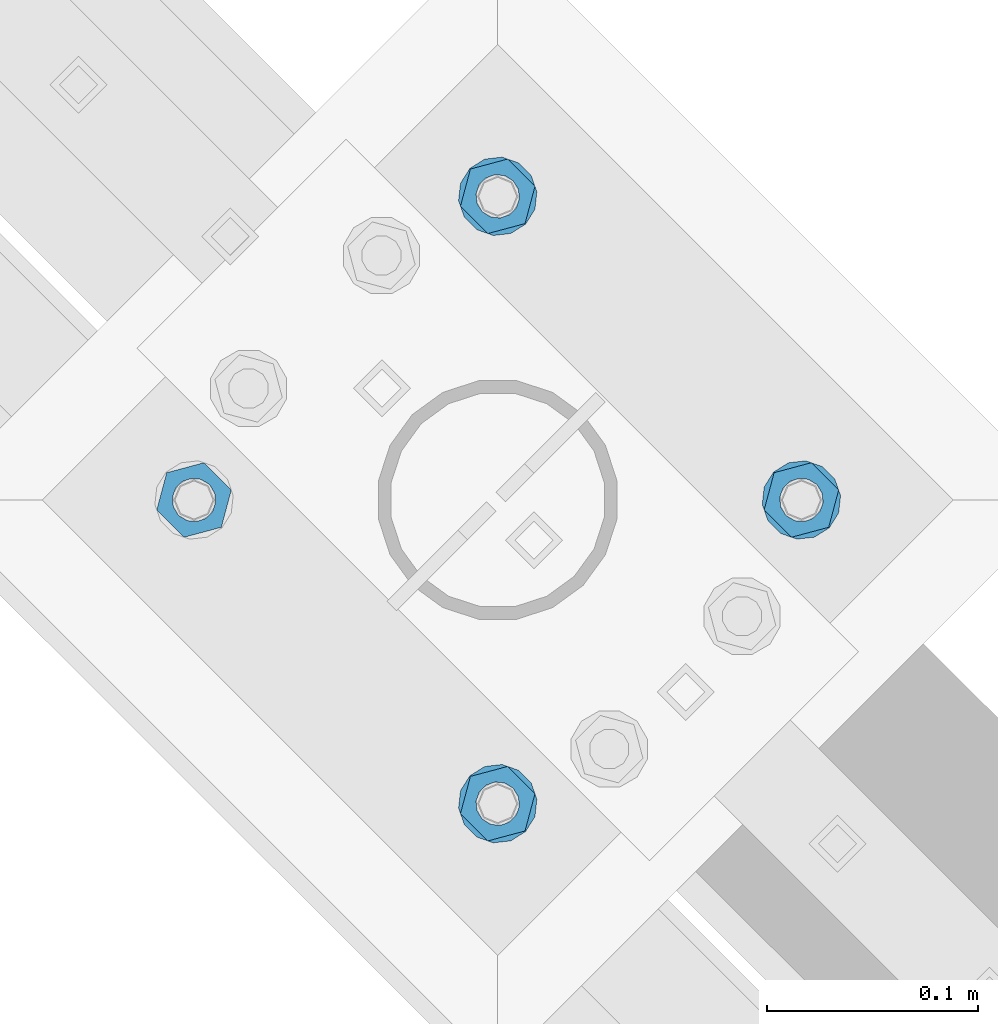
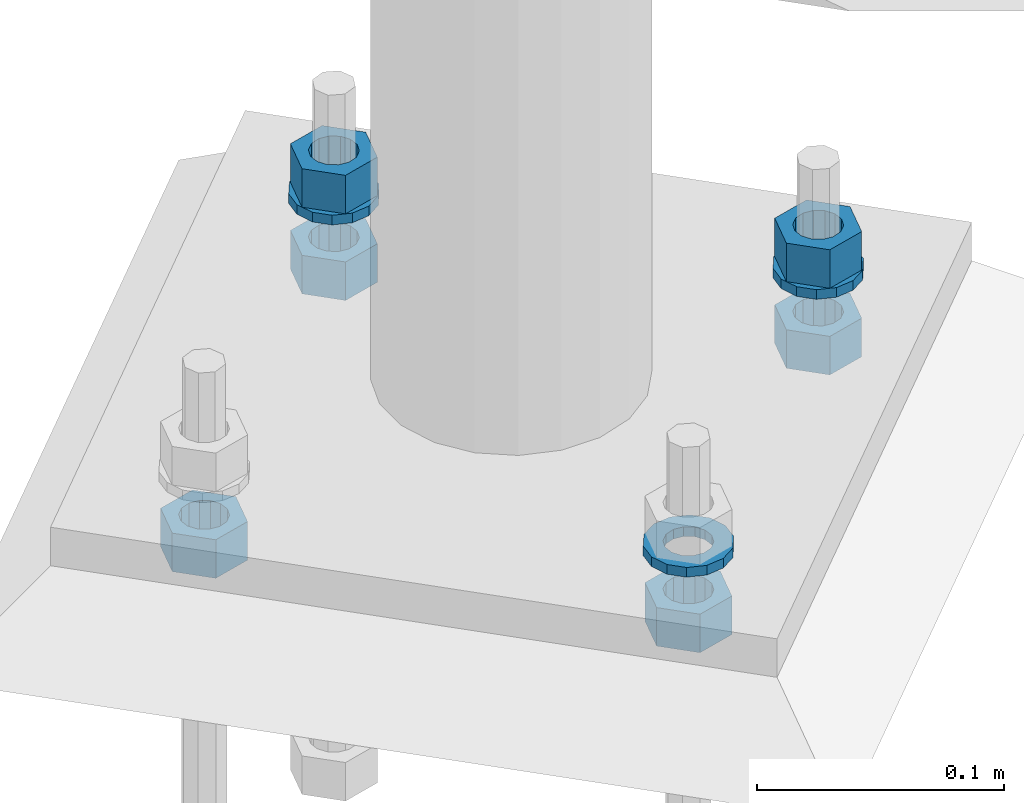
# One storey, part 828 of 975: 9 beams.
"""IFC2X3 building model written with IfcOpenShell, lengths in millimetres."""

from ifc_helpers import new_model, si_unit, frame, origin_with_axes, place, context, subcontext, project, spatial, faceted_brep, material, type_object, element, save


model = new_model("IFC2X3")

# Units and contexts
model_context = context("Model", 3, precision=1e-05, world=origin_with_axes())
body_context = subcontext(model_context, "Body", "Model", "MODEL_VIEW")
ifc_project = project(units=[si_unit("LENGTHUNIT", "METRE", prefix="MILLI"), si_unit("AREAUNIT", "SQUARE_METRE"), si_unit("VOLUMEUNIT", "CUBIC_METRE"), si_unit("MASSUNIT", "GRAM", prefix="KILO"), si_unit("TIMEUNIT", "SECOND"), si_unit("PLANEANGLEUNIT", "RADIAN"), si_unit("SOLIDANGLEUNIT", "STERADIAN"), si_unit("THERMODYNAMICTEMPERATUREUNIT", "DEGREE_CELSIUS"), si_unit("LUMINOUSINTENSITYUNIT", "LUMEN")], contexts=[model_context])

# Site, building, storey
site_placement = place(None, origin_with_axes())
site = spatial("IfcSite", under=ifc_project, at=site_placement, CompositionType="ELEMENT")
building_placement = place(site_placement, origin_with_axes())
building = spatial("IfcBuilding", under=site, at=building_placement, Name="Undefined", CompositionType="ELEMENT")
storey_placement = place(building_placement, origin_with_axes())
storey = spatial("IfcBuildingStorey", under=building, at=storey_placement, Name="Undefined", CompositionType="ELEMENT", Elevation=0.0)

# Beams
ifc_material = material(Name="STEEL/A36")
beam_type_1 = type_object("IfcBeamType", Name="3/4_WASHER", PredefinedType="NOTDEFINED")
beam_1_placement = place(storey_placement, frame((30546.675001079, 17945.8784053001, -242.8875), z_axis=(0.707106781186548, 0.707106781186548, 0.0), x_axis=(0.0, 0.0, -1.0)))
element("IfcBeam", 1, at=beam_1_placement, inside=storey, type_object=beam_type_1, material=ifc_material, Name="WASHER", ObjectType="3/4_WASHER", context=body_context, shape_type="Brep", body=[
    faceted_brep([(0.0, -18.6499996185303, 0.0), (0.0, -16.8030690426876, -8.09193156902904), (4.76250000000073, -16.8030690426876, -8.09193156902904), (4.76250000000073, -18.6499996185303, 0.0), (0.0, -11.6280845668225, -14.5811568497838), (4.76250000000073, -11.6280845668225, -14.5811568497838), (0.0, -4.15001533340001, -18.1824051902857), (4.76250000000073, -4.15001533340001, -18.1824051902857), (0.0, 4.15001533340001, -18.1824051902857), (4.76250000000073, 4.15001533340001, -18.1824051902857), (0.0, 11.6280845668234, -14.5811568497838), (4.76250000000073, 11.6280845668234, -14.5811568497838), (0.0, 16.8030690426876, -8.09193156902904), (4.76250000000073, 16.8030690426876, -8.09193156902904), (0.0, 18.6499996185303, 0.0), (4.76250000000073, 18.6499996185303, 0.0), (0.0, 16.8030690426876, 8.09193156902904), (4.76250000000073, 16.8030690426876, 8.09193156902904), (0.0, 11.6280845668225, 14.5811568497838), (4.76250000000073, 11.6280845668225, 14.5811568497838), (0.0, 4.15001533340001, 18.1824051902857), (4.76250000000073, 4.15001533340001, 18.1824051902857), (0.0, -4.15001533340001, 18.1824051902857), (4.76250000000073, -4.15001533340001, 18.1824051902857), (0.0, -11.6280845668234, 14.5811568497838), (4.76250000000073, -11.6280845668234, 14.5811568497838), (0.0, -16.8030690426876, 8.09193156902904), (4.76250000000073, -16.8030690426876, 8.09193156902904), (0.0, 0.0, 10.3199996948242), (0.0, 4.47768005528269, 9.29799844179911), (4.76250000000073, 4.47768005528269, 9.29799844179911), (4.76250000000073, 0.0, 10.3199996948242), (0.0, 8.06850066047446, 6.43441456490817), (4.76250000000073, 8.06850066047446, 6.43441456490817), (0.0, 10.0612557561917, 2.29641597052117), (4.76250000000073, 10.0612557561917, 2.29641597052117), (0.0, 10.0612557561917, -2.29641597052117), (4.76250000000073, 10.0612557561917, -2.29641597052117), (0.0, 8.06850066047446, -6.43441456490814), (4.76250000000073, 8.06850066047446, -6.43441456490814), (0.0, 4.47768005528269, -9.29799844179908), (4.76250000000073, 4.47768005528269, -9.29799844179908), (0.0, 0.0, -10.3199996948242), (4.76250000000073, 0.0, -10.3199996948242), (0.0, -4.47768005528269, -9.29799844179911), (4.76250000000073, -4.47768005528269, -9.29799844179911), (0.0, -8.06850066047446, -6.43441456490817), (4.76250000000073, -8.06850066047446, -6.43441456490817), (0.0, -10.0612557561917, -2.29641597052117), (4.76250000000073, -10.0612557561917, -2.29641597052117), (0.0, -10.0612557561917, 2.29641597052117), (4.76250000000073, -10.0612557561917, 2.29641597052117), (0.0, -8.06850066047446, 6.43441456490814), (4.76250000000073, -8.06850066047446, 6.43441456490814), (0.0, -4.47768005528269, 9.29799844179908), (4.76250000000073, -4.47768005528269, 9.29799844179908)], [[[0, 1, 2, 3]], [[1, 4, 5, 2]], [[4, 6, 7, 5]], [[6, 8, 9, 7]], [[8, 10, 11, 9]], [[10, 12, 13, 11]], [[12, 14, 15, 13]], [[14, 16, 17, 15]], [[16, 18, 19, 17]], [[18, 20, 21, 19]], [[20, 22, 23, 21]], [[22, 24, 25, 23]], [[24, 26, 27, 25]], [[26, 0, 3, 27]], [[28, 29, 30, 31]], [[29, 32, 33, 30]], [[32, 34, 35, 33]], [[34, 36, 37, 35]], [[36, 38, 39, 37]], [[38, 40, 41, 39]], [[40, 42, 43, 41]], [[42, 44, 45, 43]], [[44, 46, 47, 45]], [[46, 48, 49, 47]], [[48, 50, 51, 49]], [[50, 52, 53, 51]], [[52, 54, 55, 53]], [[54, 28, 31, 55]], [[5, 7, 9, 11, 13, 15, 17, 19, 21, 23, 25, 27, 3, 2], [33, 35, 37, 39, 41, 43, 45, 47, 49, 51, 53, 55, 31, 30]], [[26, 24, 22, 20, 18, 16, 14, 12, 10, 8, 6, 4, 1, 0], [54, 52, 50, 48, 46, 44, 42, 40, 38, 36, 34, 32, 29, 28]]]),
])
beam_2_placement = place(storey_placement, frame((30546.675001079, 18233.2465968578, -242.8875), z_axis=(-0.707106781186548, -0.707106781186548, 0.0), x_axis=(0.0, 0.0, -1.0)))
element("IfcBeam", 2, at=beam_2_placement, inside=storey, type_object=beam_type_1, material=ifc_material, Name="WASHER", ObjectType="3/4_WASHER", context=body_context, shape_type="Brep", body=[
    faceted_brep([(0.0, -18.6499996185303, 0.0), (0.0, -16.8030690426876, -8.09193156902904), (4.76250000000073, -16.8030690426876, -8.09193156902904), (4.76250000000073, -18.6499996185303, 0.0), (0.0, -11.6280845668225, -14.5811568497838), (4.76250000000073, -11.6280845668225, -14.5811568497838), (0.0, -4.15001533340001, -18.1824051902857), (4.76250000000073, -4.15001533340001, -18.1824051902857), (0.0, 4.15001533340001, -18.1824051902857), (4.76250000000073, 4.15001533340001, -18.1824051902857), (0.0, 11.6280845668234, -14.5811568497838), (4.76250000000073, 11.6280845668234, -14.5811568497838), (0.0, 16.8030690426876, -8.09193156902904), (4.76250000000073, 16.8030690426876, -8.09193156902904), (0.0, 18.6499996185303, 0.0), (4.76250000000073, 18.6499996185303, 0.0), (0.0, 16.8030690426876, 8.09193156902904), (4.76250000000073, 16.8030690426876, 8.09193156902904), (0.0, 11.6280845668225, 14.5811568497838), (4.76250000000073, 11.6280845668225, 14.5811568497838), (0.0, 4.15001533340001, 18.1824051902857), (4.76250000000073, 4.15001533340001, 18.1824051902857), (0.0, -4.15001533340001, 18.1824051902857), (4.76250000000073, -4.15001533340001, 18.1824051902857), (0.0, -11.6280845668234, 14.5811568497838), (4.76250000000073, -11.6280845668234, 14.5811568497838), (0.0, -16.8030690426876, 8.09193156902904), (4.76250000000073, -16.8030690426876, 8.09193156902904), (0.0, 0.0, 10.3199996948242), (0.0, 4.47768005528269, 9.29799844179911), (4.76250000000073, 4.47768005528269, 9.29799844179911), (4.76250000000073, 0.0, 10.3199996948242), (0.0, 8.06850066047446, 6.43441456490817), (4.76250000000073, 8.06850066047446, 6.43441456490817), (0.0, 10.0612557561917, 2.29641597052117), (4.76250000000073, 10.0612557561917, 2.29641597052117), (0.0, 10.0612557561917, -2.29641597052117), (4.76250000000073, 10.0612557561917, -2.29641597052117), (0.0, 8.06850066047446, -6.43441456490814), (4.76250000000073, 8.06850066047446, -6.43441456490814), (0.0, 4.47768005528269, -9.29799844179908), (4.76250000000073, 4.47768005528269, -9.29799844179908), (0.0, 0.0, -10.3199996948242), (4.76250000000073, 0.0, -10.3199996948242), (0.0, -4.47768005528269, -9.29799844179911), (4.76250000000073, -4.47768005528269, -9.29799844179911), (0.0, -8.06850066047446, -6.43441456490817), (4.76250000000073, -8.06850066047446, -6.43441456490817), (0.0, -10.0612557561917, -2.29641597052117), (4.76250000000073, -10.0612557561917, -2.29641597052117), (0.0, -10.0612557561917, 2.29641597052117), (4.76250000000073, -10.0612557561917, 2.29641597052117), (0.0, -8.06850066047446, 6.43441456490814), (4.76250000000073, -8.06850066047446, 6.43441456490814), (0.0, -4.47768005528269, 9.29799844179908), (4.76250000000073, -4.47768005528269, 9.29799844179908)], [[[0, 1, 2, 3]], [[1, 4, 5, 2]], [[4, 6, 7, 5]], [[6, 8, 9, 7]], [[8, 10, 11, 9]], [[10, 12, 13, 11]], [[12, 14, 15, 13]], [[14, 16, 17, 15]], [[16, 18, 19, 17]], [[18, 20, 21, 19]], [[20, 22, 23, 21]], [[22, 24, 25, 23]], [[24, 26, 27, 25]], [[26, 0, 3, 27]], [[28, 29, 30, 31]], [[29, 32, 33, 30]], [[32, 34, 35, 33]], [[34, 36, 37, 35]], [[36, 38, 39, 37]], [[38, 40, 41, 39]], [[40, 42, 43, 41]], [[42, 44, 45, 43]], [[44, 46, 47, 45]], [[46, 48, 49, 47]], [[48, 50, 51, 49]], [[50, 52, 53, 51]], [[52, 54, 55, 53]], [[54, 28, 31, 55]], [[5, 7, 9, 11, 13, 15, 17, 19, 21, 23, 25, 27, 3, 2], [33, 35, 37, 39, 41, 43, 45, 47, 49, 51, 53, 55, 31, 30]], [[26, 24, 22, 20, 18, 16, 14, 12, 10, 8, 6, 4, 1, 0], [54, 52, 50, 48, 46, 44, 42, 40, 38, 36, 34, 32, 29, 28]]]),
])
beam_3_placement = place(storey_placement, frame((30690.3590968578, 18089.562501079, -242.8875), z_axis=(0.707106781186548, 0.707106781186548, 0.0), x_axis=(0.0, 0.0, -1.0)))
element("IfcBeam", 3, at=beam_3_placement, inside=storey, type_object=beam_type_1, material=ifc_material, Name="WASHER", ObjectType="3/4_WASHER", context=body_context, shape_type="Brep", body=[
    faceted_brep([(0.0, -18.6499996185303, 0.0), (0.0, -16.8030690426876, -8.09193156902904), (4.76250000000073, -16.8030690426876, -8.09193156902904), (4.76250000000073, -18.6499996185303, 0.0), (0.0, -11.6280845668225, -14.5811568497838), (4.76250000000073, -11.6280845668225, -14.5811568497838), (0.0, -4.15001533340001, -18.1824051902857), (4.76250000000073, -4.15001533340001, -18.1824051902857), (0.0, 4.15001533340001, -18.1824051902857), (4.76250000000073, 4.15001533340001, -18.1824051902857), (0.0, 11.6280845668234, -14.5811568497838), (4.76250000000073, 11.6280845668234, -14.5811568497838), (0.0, 16.8030690426876, -8.09193156902904), (4.76250000000073, 16.8030690426876, -8.09193156902904), (0.0, 18.6499996185303, 0.0), (4.76250000000073, 18.6499996185303, 0.0), (0.0, 16.8030690426876, 8.09193156902904), (4.76250000000073, 16.8030690426876, 8.09193156902904), (0.0, 11.6280845668225, 14.5811568497838), (4.76250000000073, 11.6280845668225, 14.5811568497838), (0.0, 4.15001533340001, 18.1824051902857), (4.76250000000073, 4.15001533340001, 18.1824051902857), (0.0, -4.15001533340001, 18.1824051902857), (4.76250000000073, -4.15001533340001, 18.1824051902857), (0.0, -11.6280845668234, 14.5811568497838), (4.76250000000073, -11.6280845668234, 14.5811568497838), (0.0, -16.8030690426876, 8.09193156902904), (4.76250000000073, -16.8030690426876, 8.09193156902904), (0.0, 0.0, 10.3199996948242), (0.0, 4.47768005528269, 9.29799844179911), (4.76250000000073, 4.47768005528269, 9.29799844179911), (4.76250000000073, 0.0, 10.3199996948242), (0.0, 8.06850066047446, 6.43441456490817), (4.76250000000073, 8.06850066047446, 6.43441456490817), (0.0, 10.0612557561917, 2.29641597052117), (4.76250000000073, 10.0612557561917, 2.29641597052117), (0.0, 10.0612557561917, -2.29641597052117), (4.76250000000073, 10.0612557561917, -2.29641597052117), (0.0, 8.06850066047446, -6.43441456490814), (4.76250000000073, 8.06850066047446, -6.43441456490814), (0.0, 4.47768005528269, -9.29799844179908), (4.76250000000073, 4.47768005528269, -9.29799844179908), (0.0, 0.0, -10.3199996948242), (4.76250000000073, 0.0, -10.3199996948242), (0.0, -4.47768005528269, -9.29799844179911), (4.76250000000073, -4.47768005528269, -9.29799844179911), (0.0, -8.06850066047446, -6.43441456490817), (4.76250000000073, -8.06850066047446, -6.43441456490817), (0.0, -10.0612557561917, -2.29641597052117), (4.76250000000073, -10.0612557561917, -2.29641597052117), (0.0, -10.0612557561917, 2.29641597052117), (4.76250000000073, -10.0612557561917, 2.29641597052117), (0.0, -8.06850066047446, 6.43441456490814), (4.76250000000073, -8.06850066047446, 6.43441456490814), (0.0, -4.47768005528269, 9.29799844179908), (4.76250000000073, -4.47768005528269, 9.29799844179908)], [[[0, 1, 2, 3]], [[1, 4, 5, 2]], [[4, 6, 7, 5]], [[6, 8, 9, 7]], [[8, 10, 11, 9]], [[10, 12, 13, 11]], [[12, 14, 15, 13]], [[14, 16, 17, 15]], [[16, 18, 19, 17]], [[18, 20, 21, 19]], [[20, 22, 23, 21]], [[22, 24, 25, 23]], [[24, 26, 27, 25]], [[26, 0, 3, 27]], [[28, 29, 30, 31]], [[29, 32, 33, 30]], [[32, 34, 35, 33]], [[34, 36, 37, 35]], [[36, 38, 39, 37]], [[38, 40, 41, 39]], [[40, 42, 43, 41]], [[42, 44, 45, 43]], [[44, 46, 47, 45]], [[46, 48, 49, 47]], [[48, 50, 51, 49]], [[50, 52, 53, 51]], [[52, 54, 55, 53]], [[54, 28, 31, 55]], [[5, 7, 9, 11, 13, 15, 17, 19, 21, 23, 25, 27, 3, 2], [33, 35, 37, 39, 41, 43, 45, 47, 49, 51, 53, 55, 31, 30]], [[26, 24, 22, 20, 18, 16, 14, 12, 10, 8, 6, 4, 1, 0], [54, 52, 50, 48, 46, 44, 42, 40, 38, 36, 34, 32, 29, 28]]]),
])
beam_type_2 = type_object("IfcBeamType", Name="3/4_HEAVY_HEX_NUT", PredefinedType="NOTDEFINED")
beam_4_placement = place(storey_placement, frame((30546.675001079, 18233.2465968578, -223.837500000001), z_axis=(-0.707106781186548, -0.707106781186548, 0.0), x_axis=(0.0, 0.0, -1.0)))
element("IfcBeam", 4, at=beam_4_placement, inside=storey, type_object=beam_type_2, material=ifc_material, Name="NUT", ObjectType="3/4_HEAVY_HEX_NUT", context=body_context, shape_type="Brep", body=[
    faceted_brep([(0.0, -18.2600002288818, 0.0), (0.0, -9.13000011444092, -15.8100004196167), (19.0499999999993, -9.13000011444092, -15.8100004196167), (19.0499999999993, -18.2600002288818, 0.0), (0.0, 9.13000011444092, -15.8100004196167), (19.0499999999993, 9.13000011444092, -15.8100004196167), (0.0, 18.2600002288818, 0.0), (19.0499999999993, 18.2600002288818, 0.0), (0.0, 9.13000011444092, 15.8100004196167), (19.0499999999993, 9.13000011444092, 15.8100004196167), (0.0, -9.13000011444092, 15.8100004196167), (19.0499999999993, -9.13000011444092, 15.8100004196167), (0.0, 0.0, 10.3199996948242), (0.0, 4.47768005528269, 9.29799844179911), (19.0499999999993, 4.47768005528269, 9.29799844179911), (19.0499999999993, 0.0, 10.3199996948242), (0.0, 8.06850066047446, 6.43441456490817), (19.0499999999993, 8.06850066047446, 6.43441456490817), (0.0, 10.0612557561917, 2.29641597052117), (19.0499999999993, 10.0612557561917, 2.29641597052117), (0.0, 10.0612557561917, -2.29641597052117), (19.0499999999993, 10.0612557561917, -2.29641597052117), (0.0, 8.06850066047446, -6.43441456490814), (19.0499999999993, 8.06850066047446, -6.43441456490814), (0.0, 4.47768005528269, -9.29799844179908), (19.0499999999993, 4.47768005528269, -9.29799844179908), (0.0, 0.0, -10.3199996948242), (19.0499999999993, 0.0, -10.3199996948242), (0.0, -4.47768005528269, -9.29799844179911), (19.0499999999993, -4.47768005528269, -9.29799844179911), (0.0, -8.06850066047446, -6.43441456490817), (19.0499999999993, -8.06850066047446, -6.43441456490817), (0.0, -10.0612557561917, -2.29641597052117), (19.0499999999993, -10.0612557561917, -2.29641597052117), (0.0, -10.0612557561917, 2.29641597052117), (19.0499999999993, -10.0612557561917, 2.29641597052117), (0.0, -8.06850066047446, 6.43441456490814), (19.0499999999993, -8.06850066047446, 6.43441456490814), (0.0, -4.47768005528269, 9.29799844179908), (19.0499999999993, -4.47768005528269, 9.29799844179908)], [[[0, 1, 2, 3]], [[1, 4, 5, 2]], [[4, 6, 7, 5]], [[6, 8, 9, 7]], [[8, 10, 11, 9]], [[10, 0, 3, 11]], [[12, 13, 14, 15]], [[13, 16, 17, 14]], [[16, 18, 19, 17]], [[18, 20, 21, 19]], [[20, 22, 23, 21]], [[22, 24, 25, 23]], [[24, 26, 27, 25]], [[26, 28, 29, 27]], [[28, 30, 31, 29]], [[30, 32, 33, 31]], [[32, 34, 35, 33]], [[34, 36, 37, 35]], [[36, 38, 39, 37]], [[38, 12, 15, 39]], [[5, 7, 9, 11, 3, 2], [17, 19, 21, 23, 25, 27, 29, 31, 33, 35, 37, 39, 15, 14]], [[10, 8, 6, 4, 1, 0], [38, 36, 34, 32, 30, 28, 26, 24, 22, 20, 18, 16, 13, 12]]]),
])
beam_5_placement = place(storey_placement, frame((30690.3590968578, 18089.562501079, -223.837500000001), z_axis=(0.707106781186548, 0.707106781186548, 0.0), x_axis=(0.0, 0.0, -1.0)))
element("IfcBeam", 5, at=beam_5_placement, inside=storey, type_object=beam_type_2, material=ifc_material, Name="NUT", ObjectType="3/4_HEAVY_HEX_NUT", context=body_context, shape_type="Brep", body=[
    faceted_brep([(0.0, -18.2600002288818, 0.0), (0.0, -9.13000011444092, -15.8100004196167), (19.0499999999993, -9.13000011444092, -15.8100004196167), (19.0499999999993, -18.2600002288818, 0.0), (0.0, 9.13000011444092, -15.8100004196167), (19.0499999999993, 9.13000011444092, -15.8100004196167), (0.0, 18.2600002288818, 0.0), (19.0499999999993, 18.2600002288818, 0.0), (0.0, 9.13000011444092, 15.8100004196167), (19.0499999999993, 9.13000011444092, 15.8100004196167), (0.0, -9.13000011444092, 15.8100004196167), (19.0499999999993, -9.13000011444092, 15.8100004196167), (0.0, 0.0, 10.3199996948242), (0.0, 4.47768005528269, 9.29799844179911), (19.0499999999993, 4.47768005528269, 9.29799844179911), (19.0499999999993, 0.0, 10.3199996948242), (0.0, 8.06850066047446, 6.43441456490817), (19.0499999999993, 8.06850066047446, 6.43441456490817), (0.0, 10.0612557561917, 2.29641597052117), (19.0499999999993, 10.0612557561917, 2.29641597052117), (0.0, 10.0612557561917, -2.29641597052117), (19.0499999999993, 10.0612557561917, -2.29641597052117), (0.0, 8.06850066047446, -6.43441456490814), (19.0499999999993, 8.06850066047446, -6.43441456490814), (0.0, 4.47768005528269, -9.29799844179908), (19.0499999999993, 4.47768005528269, -9.29799844179908), (0.0, 0.0, -10.3199996948242), (19.0499999999993, 0.0, -10.3199996948242), (0.0, -4.47768005528269, -9.29799844179911), (19.0499999999993, -4.47768005528269, -9.29799844179911), (0.0, -8.06850066047446, -6.43441456490817), (19.0499999999993, -8.06850066047446, -6.43441456490817), (0.0, -10.0612557561917, -2.29641597052117), (19.0499999999993, -10.0612557561917, -2.29641597052117), (0.0, -10.0612557561917, 2.29641597052117), (19.0499999999993, -10.0612557561917, 2.29641597052117), (0.0, -8.06850066047446, 6.43441456490814), (19.0499999999993, -8.06850066047446, 6.43441456490814), (0.0, -4.47768005528269, 9.29799844179908), (19.0499999999993, -4.47768005528269, 9.29799844179908)], [[[0, 1, 2, 3]], [[1, 4, 5, 2]], [[4, 6, 7, 5]], [[6, 8, 9, 7]], [[8, 10, 11, 9]], [[10, 0, 3, 11]], [[12, 13, 14, 15]], [[13, 16, 17, 14]], [[16, 18, 19, 17]], [[18, 20, 21, 19]], [[20, 22, 23, 21]], [[22, 24, 25, 23]], [[24, 26, 27, 25]], [[26, 28, 29, 27]], [[28, 30, 31, 29]], [[30, 32, 33, 31]], [[32, 34, 35, 33]], [[34, 36, 37, 35]], [[36, 38, 39, 37]], [[38, 12, 15, 39]], [[5, 7, 9, 11, 3, 2], [17, 19, 21, 23, 25, 27, 29, 31, 33, 35, 37, 39, 15, 14]], [[10, 8, 6, 4, 1, 0], [38, 36, 34, 32, 30, 28, 26, 24, 22, 20, 18, 16, 13, 12]]]),
])
beam_6_placement = place(storey_placement, frame((30402.9909053001, 18089.562501079, -266.7), z_axis=(-0.707106781186548, -0.707106781186548, 0.0), x_axis=(0.0, 0.0, -1.0)))
element("IfcBeam", 6, at=beam_6_placement, inside=storey, type_object=beam_type_2, material=ifc_material, Name="NUT", ObjectType="3/4_HEAVY_HEX_NUT", context=body_context, shape_type="Brep", body=[
    faceted_brep([(0.0, -18.2600002288818, 0.0), (0.0, -9.13000011444092, -15.8100004196167), (19.0499999999993, -9.13000011444092, -15.8100004196167), (19.0499999999993, -18.2600002288818, 0.0), (0.0, 9.13000011444092, -15.8100004196167), (19.0499999999993, 9.13000011444092, -15.8100004196167), (0.0, 18.2600002288818, 0.0), (19.0499999999993, 18.2600002288818, 0.0), (0.0, 9.13000011444092, 15.8100004196167), (19.0499999999993, 9.13000011444092, 15.8100004196167), (0.0, -9.13000011444092, 15.8100004196167), (19.0499999999993, -9.13000011444092, 15.8100004196167), (0.0, 0.0, 10.3199996948242), (0.0, 4.47768005528269, 9.29799844179911), (19.0499999999993, 4.47768005528269, 9.29799844179911), (19.0499999999993, 0.0, 10.3199996948242), (0.0, 8.06850066047446, 6.43441456490817), (19.0499999999993, 8.06850066047446, 6.43441456490817), (0.0, 10.0612557561917, 2.29641597052117), (19.0499999999993, 10.0612557561917, 2.29641597052117), (0.0, 10.0612557561917, -2.29641597052117), (19.0499999999993, 10.0612557561917, -2.29641597052117), (0.0, 8.06850066047446, -6.43441456490814), (19.0499999999993, 8.06850066047446, -6.43441456490814), (0.0, 4.47768005528269, -9.29799844179908), (19.0499999999993, 4.47768005528269, -9.29799844179908), (0.0, 0.0, -10.3199996948242), (19.0499999999993, 0.0, -10.3199996948242), (0.0, -4.47768005528269, -9.29799844179911), (19.0499999999993, -4.47768005528269, -9.29799844179911), (0.0, -8.06850066047446, -6.43441456490817), (19.0499999999993, -8.06850066047446, -6.43441456490817), (0.0, -10.0612557561917, -2.29641597052117), (19.0499999999993, -10.0612557561917, -2.29641597052117), (0.0, -10.0612557561917, 2.29641597052117), (19.0499999999993, -10.0612557561917, 2.29641597052117), (0.0, -8.06850066047446, 6.43441456490814), (19.0499999999993, -8.06850066047446, 6.43441456490814), (0.0, -4.47768005528269, 9.29799844179908), (19.0499999999993, -4.47768005528269, 9.29799844179908)], [[[0, 1, 2, 3]], [[1, 4, 5, 2]], [[4, 6, 7, 5]], [[6, 8, 9, 7]], [[8, 10, 11, 9]], [[10, 0, 3, 11]], [[12, 13, 14, 15]], [[13, 16, 17, 14]], [[16, 18, 19, 17]], [[18, 20, 21, 19]], [[20, 22, 23, 21]], [[22, 24, 25, 23]], [[24, 26, 27, 25]], [[26, 28, 29, 27]], [[28, 30, 31, 29]], [[30, 32, 33, 31]], [[32, 34, 35, 33]], [[34, 36, 37, 35]], [[36, 38, 39, 37]], [[38, 12, 15, 39]], [[5, 7, 9, 11, 3, 2], [17, 19, 21, 23, 25, 27, 29, 31, 33, 35, 37, 39, 15, 14]], [[10, 8, 6, 4, 1, 0], [38, 36, 34, 32, 30, 28, 26, 24, 22, 20, 18, 16, 13, 12]]]),
])
beam_7_placement = place(storey_placement, frame((30546.675001079, 17945.8784053001, -266.7), z_axis=(0.707106781186548, 0.707106781186548, 0.0), x_axis=(0.0, 0.0, -1.0)))
element("IfcBeam", 7, at=beam_7_placement, inside=storey, type_object=beam_type_2, material=ifc_material, Name="NUT", ObjectType="3/4_HEAVY_HEX_NUT", context=body_context, shape_type="Brep", body=[
    faceted_brep([(0.0, -18.2600002288818, 0.0), (0.0, -9.13000011444092, -15.8100004196167), (19.0499999999993, -9.13000011444092, -15.8100004196167), (19.0499999999993, -18.2600002288818, 0.0), (0.0, 9.13000011444092, -15.8100004196167), (19.0499999999993, 9.13000011444092, -15.8100004196167), (0.0, 18.2600002288818, 0.0), (19.0499999999993, 18.2600002288818, 0.0), (0.0, 9.13000011444092, 15.8100004196167), (19.0499999999993, 9.13000011444092, 15.8100004196167), (0.0, -9.13000011444092, 15.8100004196167), (19.0499999999993, -9.13000011444092, 15.8100004196167), (0.0, 0.0, 10.3199996948242), (0.0, 4.47768005528269, 9.29799844179911), (19.0499999999993, 4.47768005528269, 9.29799844179911), (19.0499999999993, 0.0, 10.3199996948242), (0.0, 8.06850066047446, 6.43441456490817), (19.0499999999993, 8.06850066047446, 6.43441456490817), (0.0, 10.0612557561917, 2.29641597052117), (19.0499999999993, 10.0612557561917, 2.29641597052117), (0.0, 10.0612557561917, -2.29641597052117), (19.0499999999993, 10.0612557561917, -2.29641597052117), (0.0, 8.06850066047446, -6.43441456490814), (19.0499999999993, 8.06850066047446, -6.43441456490814), (0.0, 4.47768005528269, -9.29799844179908), (19.0499999999993, 4.47768005528269, -9.29799844179908), (0.0, 0.0, -10.3199996948242), (19.0499999999993, 0.0, -10.3199996948242), (0.0, -4.47768005528269, -9.29799844179911), (19.0499999999993, -4.47768005528269, -9.29799844179911), (0.0, -8.06850066047446, -6.43441456490817), (19.0499999999993, -8.06850066047446, -6.43441456490817), (0.0, -10.0612557561917, -2.29641597052117), (19.0499999999993, -10.0612557561917, -2.29641597052117), (0.0, -10.0612557561917, 2.29641597052117), (19.0499999999993, -10.0612557561917, 2.29641597052117), (0.0, -8.06850066047446, 6.43441456490814), (19.0499999999993, -8.06850066047446, 6.43441456490814), (0.0, -4.47768005528269, 9.29799844179908), (19.0499999999993, -4.47768005528269, 9.29799844179908)], [[[0, 1, 2, 3]], [[1, 4, 5, 2]], [[4, 6, 7, 5]], [[6, 8, 9, 7]], [[8, 10, 11, 9]], [[10, 0, 3, 11]], [[12, 13, 14, 15]], [[13, 16, 17, 14]], [[16, 18, 19, 17]], [[18, 20, 21, 19]], [[20, 22, 23, 21]], [[22, 24, 25, 23]], [[24, 26, 27, 25]], [[26, 28, 29, 27]], [[28, 30, 31, 29]], [[30, 32, 33, 31]], [[32, 34, 35, 33]], [[34, 36, 37, 35]], [[36, 38, 39, 37]], [[38, 12, 15, 39]], [[5, 7, 9, 11, 3, 2], [17, 19, 21, 23, 25, 27, 29, 31, 33, 35, 37, 39, 15, 14]], [[10, 8, 6, 4, 1, 0], [38, 36, 34, 32, 30, 28, 26, 24, 22, 20, 18, 16, 13, 12]]]),
])
beam_8_placement = place(storey_placement, frame((30546.675001079, 18233.2465968578, -266.7), z_axis=(-0.707106781186548, -0.707106781186548, 0.0), x_axis=(0.0, 0.0, -1.0)))
element("IfcBeam", 8, at=beam_8_placement, inside=storey, type_object=beam_type_2, material=ifc_material, Name="NUT", ObjectType="3/4_HEAVY_HEX_NUT", context=body_context, shape_type="Brep", body=[
    faceted_brep([(0.0, -18.2600002288818, 0.0), (0.0, -9.13000011444092, -15.8100004196167), (19.0499999999993, -9.13000011444092, -15.8100004196167), (19.0499999999993, -18.2600002288818, 0.0), (0.0, 9.13000011444092, -15.8100004196167), (19.0499999999993, 9.13000011444092, -15.8100004196167), (0.0, 18.2600002288818, 0.0), (19.0499999999993, 18.2600002288818, 0.0), (0.0, 9.13000011444092, 15.8100004196167), (19.0499999999993, 9.13000011444092, 15.8100004196167), (0.0, -9.13000011444092, 15.8100004196167), (19.0499999999993, -9.13000011444092, 15.8100004196167), (0.0, 0.0, 10.3199996948242), (0.0, 4.47768005528269, 9.29799844179911), (19.0499999999993, 4.47768005528269, 9.29799844179911), (19.0499999999993, 0.0, 10.3199996948242), (0.0, 8.06850066047446, 6.43441456490817), (19.0499999999993, 8.06850066047446, 6.43441456490817), (0.0, 10.0612557561917, 2.29641597052117), (19.0499999999993, 10.0612557561917, 2.29641597052117), (0.0, 10.0612557561917, -2.29641597052117), (19.0499999999993, 10.0612557561917, -2.29641597052117), (0.0, 8.06850066047446, -6.43441456490814), (19.0499999999993, 8.06850066047446, -6.43441456490814), (0.0, 4.47768005528269, -9.29799844179908), (19.0499999999993, 4.47768005528269, -9.29799844179908), (0.0, 0.0, -10.3199996948242), (19.0499999999993, 0.0, -10.3199996948242), (0.0, -4.47768005528269, -9.29799844179911), (19.0499999999993, -4.47768005528269, -9.29799844179911), (0.0, -8.06850066047446, -6.43441456490817), (19.0499999999993, -8.06850066047446, -6.43441456490817), (0.0, -10.0612557561917, -2.29641597052117), (19.0499999999993, -10.0612557561917, -2.29641597052117), (0.0, -10.0612557561917, 2.29641597052117), (19.0499999999993, -10.0612557561917, 2.29641597052117), (0.0, -8.06850066047446, 6.43441456490814), (19.0499999999993, -8.06850066047446, 6.43441456490814), (0.0, -4.47768005528269, 9.29799844179908), (19.0499999999993, -4.47768005528269, 9.29799844179908)], [[[0, 1, 2, 3]], [[1, 4, 5, 2]], [[4, 6, 7, 5]], [[6, 8, 9, 7]], [[8, 10, 11, 9]], [[10, 0, 3, 11]], [[12, 13, 14, 15]], [[13, 16, 17, 14]], [[16, 18, 19, 17]], [[18, 20, 21, 19]], [[20, 22, 23, 21]], [[22, 24, 25, 23]], [[24, 26, 27, 25]], [[26, 28, 29, 27]], [[28, 30, 31, 29]], [[30, 32, 33, 31]], [[32, 34, 35, 33]], [[34, 36, 37, 35]], [[36, 38, 39, 37]], [[38, 12, 15, 39]], [[5, 7, 9, 11, 3, 2], [17, 19, 21, 23, 25, 27, 29, 31, 33, 35, 37, 39, 15, 14]], [[10, 8, 6, 4, 1, 0], [38, 36, 34, 32, 30, 28, 26, 24, 22, 20, 18, 16, 13, 12]]]),
])
beam_9_placement = place(storey_placement, frame((30690.3590968578, 18089.562501079, -266.7), z_axis=(0.707106781186548, 0.707106781186548, 0.0), x_axis=(0.0, 0.0, -1.0)))
element("IfcBeam", 9, at=beam_9_placement, inside=storey, type_object=beam_type_2, material=ifc_material, Name="NUT", ObjectType="3/4_HEAVY_HEX_NUT", context=body_context, shape_type="Brep", body=[
    faceted_brep([(0.0, -18.2600002288818, 0.0), (0.0, -9.13000011444092, -15.8100004196167), (19.0499999999993, -9.13000011444092, -15.8100004196167), (19.0499999999993, -18.2600002288818, 0.0), (0.0, 9.13000011444092, -15.8100004196167), (19.0499999999993, 9.13000011444092, -15.8100004196167), (0.0, 18.2600002288818, 0.0), (19.0499999999993, 18.2600002288818, 0.0), (0.0, 9.13000011444092, 15.8100004196167), (19.0499999999993, 9.13000011444092, 15.8100004196167), (0.0, -9.13000011444092, 15.8100004196167), (19.0499999999993, -9.13000011444092, 15.8100004196167), (0.0, 0.0, 10.3199996948242), (0.0, 4.47768005528269, 9.29799844179911), (19.0499999999993, 4.47768005528269, 9.29799844179911), (19.0499999999993, 0.0, 10.3199996948242), (0.0, 8.06850066047446, 6.43441456490817), (19.0499999999993, 8.06850066047446, 6.43441456490817), (0.0, 10.0612557561917, 2.29641597052117), (19.0499999999993, 10.0612557561917, 2.29641597052117), (0.0, 10.0612557561917, -2.29641597052117), (19.0499999999993, 10.0612557561917, -2.29641597052117), (0.0, 8.06850066047446, -6.43441456490814), (19.0499999999993, 8.06850066047446, -6.43441456490814), (0.0, 4.47768005528269, -9.29799844179908), (19.0499999999993, 4.47768005528269, -9.29799844179908), (0.0, 0.0, -10.3199996948242), (19.0499999999993, 0.0, -10.3199996948242), (0.0, -4.47768005528269, -9.29799844179911), (19.0499999999993, -4.47768005528269, -9.29799844179911), (0.0, -8.06850066047446, -6.43441456490817), (19.0499999999993, -8.06850066047446, -6.43441456490817), (0.0, -10.0612557561917, -2.29641597052117), (19.0499999999993, -10.0612557561917, -2.29641597052117), (0.0, -10.0612557561917, 2.29641597052117), (19.0499999999993, -10.0612557561917, 2.29641597052117), (0.0, -8.06850066047446, 6.43441456490814), (19.0499999999993, -8.06850066047446, 6.43441456490814), (0.0, -4.47768005528269, 9.29799844179908), (19.0499999999993, -4.47768005528269, 9.29799844179908)], [[[0, 1, 2, 3]], [[1, 4, 5, 2]], [[4, 6, 7, 5]], [[6, 8, 9, 7]], [[8, 10, 11, 9]], [[10, 0, 3, 11]], [[12, 13, 14, 15]], [[13, 16, 17, 14]], [[16, 18, 19, 17]], [[18, 20, 21, 19]], [[20, 22, 23, 21]], [[22, 24, 25, 23]], [[24, 26, 27, 25]], [[26, 28, 29, 27]], [[28, 30, 31, 29]], [[30, 32, 33, 31]], [[32, 34, 35, 33]], [[34, 36, 37, 35]], [[36, 38, 39, 37]], [[38, 12, 15, 39]], [[5, 7, 9, 11, 3, 2], [17, 19, 21, 23, 25, 27, 29, 31, 33, 35, 37, 39, 15, 14]], [[10, 8, 6, 4, 1, 0], [38, 36, 34, 32, 30, 28, 26, 24, 22, 20, 18, 16, 13, 12]]]),
])

save(model, "model.ifc")
